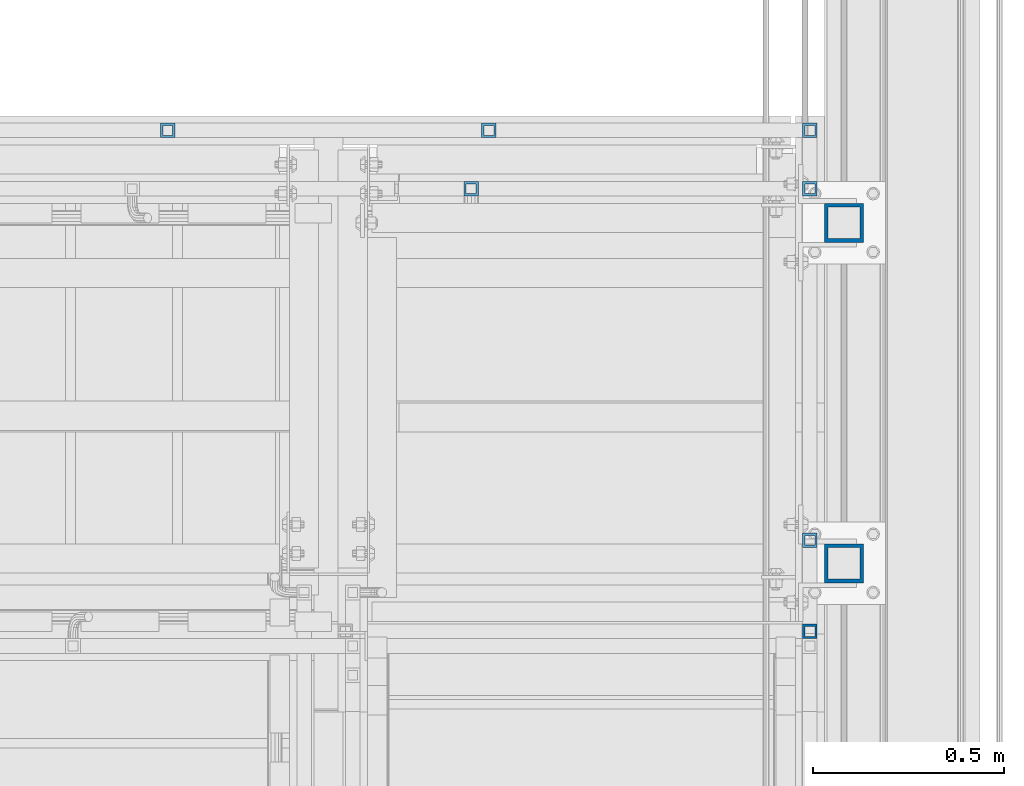
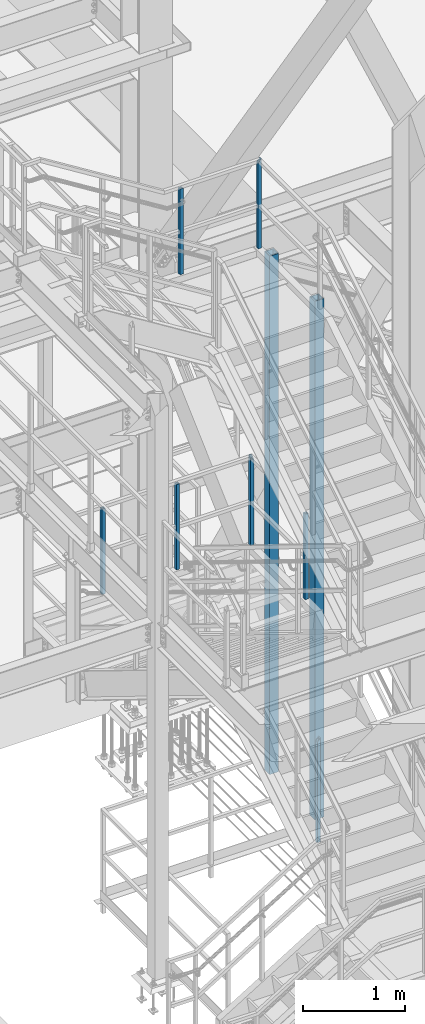
# One storey, part 1298 of 3843: 9 columns, 6 elements without a shape of their own.
"""IFC2X3 building model written with IfcOpenShell, lengths in millimetres."""

from ifc_helpers import new_model, si_unit, frame, origin_with_axes, place, context, subcontext, project, spatial, faceted_brep, material, type_object, element, aggregate, save


model = new_model("IFC2X3")

# Units and contexts
model_context = context("Model", 3, precision=1e-05, world=origin_with_axes())
body_context = subcontext(model_context, "Body", "Model", "MODEL_VIEW")
ifc_project = project(units=[si_unit("LENGTHUNIT", "METRE", prefix="MILLI"), si_unit("AREAUNIT", "SQUARE_METRE"), si_unit("VOLUMEUNIT", "CUBIC_METRE"), si_unit("MASSUNIT", "GRAM", prefix="KILO"), si_unit("TIMEUNIT", "SECOND"), si_unit("PLANEANGLEUNIT", "RADIAN"), si_unit("SOLIDANGLEUNIT", "STERADIAN"), si_unit("THERMODYNAMICTEMPERATUREUNIT", "DEGREE_CELSIUS"), si_unit("LUMINOUSINTENSITYUNIT", "LUMEN")], contexts=[model_context])

# Site, building, storey
site_placement = place(None, origin_with_axes())
site = spatial("IfcSite", under=ifc_project, at=site_placement, CompositionType="ELEMENT")
building_placement = place(site_placement, origin_with_axes())
building = spatial("IfcBuilding", under=site, at=building_placement, Name="Undefined", CompositionType="ELEMENT")
storey_placement = place(building_placement, origin_with_axes())
storey = spatial("IfcBuildingStorey", under=building, at=storey_placement, Name="Undefined", CompositionType="ELEMENT", Elevation=0.0)

# Assembly, column
assembly_1_placement = place(storey_placement, origin_with_axes())
assembly_1 = element("IfcElementAssembly", 1, at=assembly_1_placement, inside=storey, Name="RAIL", AssemblyPlace="NOTDEFINED", PredefinedType="RIGID_FRAME")
ifc_material_1 = material()
column_type_1 = type_object("IfcColumnType", Name="HSS1-1/2X1-1/2X1/4", PredefinedType="NOTDEFINED")
column_1_placement = place(assembly_1_placement, frame((55638.6999998292, 21755.0999999874, 30480.0), z_axis=(-1.0, 0.0, 0.0), x_axis=(0.0, 0.0, 1.0)))
column_1 = element("IfcColumn", 2, at=column_1_placement, type_object=column_type_1, material=ifc_material_1, Name="POST", ObjectType="HSS1-1/2X1-1/2X1/4", context=body_context, shape_type="Brep", body=[
    faceted_brep([(-152.399999977541, 12.6999993299978, -12.6999993299978), (-152.399999977541, -12.6999993299978, -12.6999993299978), (1079.49999933128, -12.6999993300014, -12.6999993299978), (1079.49999933128, 12.6999993300014, -12.6999993299978), (-152.399999977541, -12.6999993299978, 12.6999993299978), (1054.10000067129, -12.6999993300014, 12.6999993299978), (-152.399999977541, 12.6999993299978, 12.6999993299978), (1054.10000067129, 12.6999993300014, 12.6999993299978), (-152.399999977541, 19.0499992350015, -19.0499992349942), (-152.399999977541, 19.0499992350015, 19.0499992349942), (1047.75000076629, 19.0499992350015, 19.0499992349942), (1085.84999923629, 19.0499992350015, -19.0499992349942), (-152.399999977541, -19.0499992350015, 19.0499992349942), (1047.75000076629, -19.0499992350015, 19.0499992349942), (-152.399999977541, -19.0499992350015, -19.0499992349942), (1085.84999923629, -19.0499992350015, -19.0499992349942)], [[[0, 1, 2, 3]], [[1, 4, 5, 2]], [[4, 6, 7, 5]], [[6, 0, 3, 7]], [[8, 9, 10, 11]], [[9, 12, 13, 10]], [[12, 14, 15, 13]], [[14, 8, 11, 15]], [[13, 15, 11, 10], [5, 7, 3, 2]], [[14, 12, 9, 8], [6, 4, 1, 0]]]),
])
aggregate(assembly_1, [column_1])

# Assembly, columns
assembly_2_placement = place(storey_placement, origin_with_axes())
assembly_2 = element("IfcElementAssembly", 3, at=assembly_2_placement, inside=storey, Name="RAIL", AssemblyPlace="NOTDEFINED", PredefinedType="RIGID_FRAME")
column_2_placement = place(assembly_2_placement, frame((54753.9333333121, 22910.8000000151, 36694.5333312991), z_axis=(1.0, 0.0, 0.0), x_axis=(0.0, 0.0, 1.0)))
column_2 = element("IfcColumn", 4, at=column_2_placement, type_object=column_type_1, material=ifc_material_1, Name="POST", ObjectType="HSS1-1/2X1-1/2X1/4", context=body_context, shape_type="Brep", body=[
    faceted_brep([(1047.75000076629, -19.0499992350015, 19.0499992349942), (1047.750000765, -19.0499992350015, -19.0499992350015), (1047.750000765, 19.0499992350015, -19.0499992350015), (1047.75000076629, 19.0499992350015, 19.0499992349942), (1047.75000076497, -12.6999993300014, 12.6999993299978), (1047.75000076497, 12.6999993300014, 12.6999993299978), (1047.75000076497, 12.6999993300014, -12.6999993299978), (1047.75000076497, -12.6999993300014, -12.6999993299978), (25.4000000135893, 19.0499992350015, 19.0499992349942), (25.4000000135893, -19.0499992350015, 19.0499992349942), (25.4000000135893, -19.0499992350015, -19.0499992349942), (25.4000000135893, 19.0499992350015, -19.0499992349942), (25.4000000135893, 12.6999993300014, -12.6999993299978), (25.4000000135893, 12.6999993300014, 12.6999993299978), (25.4000000135893, -12.6999993300014, 12.6999993299978), (25.4000000135893, -12.6999993300014, -12.6999993299978)], [[[0, 1, 2, 3], [4, 5, 6, 7]], [[0, 3, 8, 9]], [[2, 1, 10, 11]], [[1, 0, 9, 10]], [[3, 2, 11, 8]], [[11, 10, 9, 8], [12, 13, 14, 15]], [[4, 7, 15, 14]], [[7, 6, 12, 15]], [[6, 5, 13, 12]], [[5, 4, 14, 13]]]),
])
column_3_placement = place(assembly_2_placement, frame((55638.700000001, 22910.8000000151, 36694.5333312991), z_axis=(1.0, 0.0, 0.0), x_axis=(0.0, 0.0, 1.0)))
column_3 = element("IfcColumn", 5, at=column_3_placement, type_object=column_type_1, material=ifc_material_1, Name="POST", ObjectType="HSS1-1/2X1-1/2X1/4", context=body_context, shape_type="Brep", body=[
    faceted_brep([(25.4000000135893, 12.6999993300014, -12.6999993299978), (25.4000000135893, -12.6999993300014, -12.6999993299978), (1054.10000067001, -12.6999993300014, -12.6999993299978), (1054.10000067001, 12.6999993300014, -12.6999993299978), (25.4000000135893, -12.6999993300014, 12.6999993299978), (1079.49999933, -12.6999993300014, 12.6999993299978), (25.4000000135893, 12.6999993300014, 12.6999993299978), (1079.49999933, 12.6999993300014, 12.6999993299978), (25.4000000135893, 19.0499992350015, -19.0499992349942), (25.4000000135893, 19.0499992350015, 19.0499992349942), (1085.849999235, 19.0499992350015, 19.0499992350015), (1047.750000765, 19.0499992350015, -19.0499992350015), (25.4000000135893, -19.0499992350015, 19.0499992349942), (1085.849999235, -19.0499992350015, 19.0499992350015), (25.4000000135893, -19.0499992350015, -19.0499992349942), (1047.750000765, -19.0499992350015, -19.0499992350015)], [[[0, 1, 2, 3]], [[1, 4, 5, 2]], [[4, 6, 7, 5]], [[6, 0, 3, 7]], [[8, 9, 10, 11]], [[9, 12, 13, 10]], [[12, 14, 15, 13]], [[11, 15, 14, 8]], [[13, 15, 11, 10], [5, 7, 3, 2]], [[8, 14, 12, 9], [0, 6, 4, 1]]]),
])
aggregate(assembly_2, [column_2, column_3])

assembly_3_placement = place(storey_placement, origin_with_axes())
assembly_3 = element("IfcElementAssembly", 6, at=assembly_3_placement, inside=storey, Name="RAIL", AssemblyPlace="NOTDEFINED", PredefinedType="RIGID_FRAME")
column_4_placement = place(assembly_3_placement, frame((53962.2999999994, 23063.2000000032, 33084.4769212707), z_axis=(0.0, -1.0, 0.0), x_axis=(0.0, 0.0, 1.0)))
column_4 = element("IfcColumn", 7, at=column_4_placement, type_object=column_type_1, material=ifc_material_1, Name="POST", ObjectType="HSS1-1/2X1-1/2X1/4", context=body_context, shape_type="Brep", body=[
    faceted_brep([(0.0, 12.6999993299978, -12.6999993300014), (0.0, -12.6999993299978, -12.6999993300014), (1022.35000076501, -12.6999993299978, -12.6999993300014), (1022.35000076501, 12.6999993299978, -12.6999993300014), (0.0, -12.6999993299978, 12.6999993300014), (1022.35000076501, -12.6999993299978, 12.6999993300014), (0.0, 12.6999993299978, 12.6999993300014), (1022.35000076501, 12.6999993299978, 12.6999993300014), (0.0, 19.0500000000029, -19.0499999999993), (0.0, 19.0499992350015, 19.0499992350015), (1022.35000076501, 19.0499992350015, 19.0499992350015), (1022.35000076501, 19.0499992350015, -19.0499992350015), (0.0, -19.0499992350015, 19.0499992350015), (1022.35000076501, -19.0499992350015, 19.0499992350015), (0.0, -19.0499992350015, -19.0499992350015), (1022.35000076501, -19.0499992350015, -19.0499992350015)], [[[0, 1, 2, 3]], [[1, 4, 5, 2]], [[4, 6, 7, 5]], [[6, 0, 3, 7]], [[8, 9, 10, 11]], [[9, 12, 13, 10]], [[12, 14, 15, 13]], [[14, 8, 11, 15]], [[13, 15, 11, 10], [5, 7, 3, 2]], [[14, 12, 9, 8], [6, 4, 1, 0]]]),
])
column_5_placement = place(assembly_3_placement, frame((54800.4999999997, 23063.2000000032, 33084.4769212707), z_axis=(0.0, -1.0, 0.0), x_axis=(0.0, 0.0, 1.0)))
column_5 = element("IfcColumn", 8, at=column_5_placement, type_object=column_type_1, material=ifc_material_1, Name="POST", ObjectType="HSS1-1/2X1-1/2X1/4", context=body_context, shape_type="Brep", body=[
    faceted_brep([(0.0, 12.6999993299978, -12.6999993300014), (0.0, -12.6999993299978, -12.6999993300014), (1022.35000076501, -12.6999993299978, -12.6999993300014), (1022.35000076501, 12.6999993299978, -12.6999993300014), (0.0, -12.6999993299978, 12.6999993300014), (1022.35000076501, -12.6999993299978, 12.6999993300014), (0.0, 12.6999993299978, 12.6999993300014), (1022.35000076501, 12.6999993299978, 12.6999993300014), (0.0, 19.0500000000029, -19.0499999999993), (0.0, 19.0499992350015, 19.0499992350015), (1022.35000076501, 19.0499992350015, 19.0499992350015), (1022.35000076501, 19.0499992350015, -19.0499992350015), (0.0, -19.0499992350015, 19.0499992350015), (1022.35000076501, -19.0499992350015, 19.0499992350015), (0.0, -19.0499992350015, -19.0499992350015), (1022.35000076501, -19.0499992350015, -19.0499992350015)], [[[0, 1, 2, 3]], [[1, 4, 5, 2]], [[4, 6, 7, 5]], [[6, 0, 3, 7]], [[8, 9, 10, 11]], [[9, 12, 13, 10]], [[12, 14, 15, 13]], [[14, 8, 11, 15]], [[13, 15, 11, 10], [5, 7, 3, 2]], [[14, 12, 9, 8], [6, 4, 1, 0]]]),
])
aggregate(assembly_3, [column_4, column_5])

assembly_4_placement = place(storey_placement, origin_with_axes())
assembly_4 = element("IfcElementAssembly", 9, at=assembly_4_placement, inside=storey, Name="RAIL", AssemblyPlace="NOTDEFINED", PredefinedType="RIGID_FRAME")
column_6_placement = place(assembly_4_placement, frame((55638.7, 23063.2000000032, 33059.0769213117), z_axis=(0.0, -1.0, 0.0), x_axis=(0.0, 0.0, 1.0)))
column_6 = element("IfcColumn", 10, at=column_6_placement, type_object=column_type_1, material=ifc_material_1, Name="POST", ObjectType="HSS1-1/2X1-1/2X1/4", context=body_context, shape_type="Brep", body=[
    faceted_brep([(1047.75000076629, -19.0499992350015, 19.0499992349942), (1047.75000076629, 19.0499992350015, 19.0499992349942), (25.4000000135893, 19.0499992350015, 19.0499992349942), (25.4000000135893, -19.0499992350015, 19.0499992349942), (1085.84999923629, -19.0499992350015, -19.0499992349942), (25.4000000135893, -19.0499992350015, -19.0499992349942), (1085.84999923629, 19.0499992350015, -19.0499992349942), (25.4000000135893, 19.0499992350015, -19.0499992349942), (1054.10000067129, -12.6999993300014, 12.6999993299978), (1054.10000067129, 12.6999993300014, 12.6999993299978), (1079.49999933128, 12.6999993300014, -12.6999993299978), (1079.49999933128, -12.6999993300014, -12.6999993299978), (25.4000000135893, -12.6999993300014, 12.6999993299978), (25.4000000135893, 12.6999993300014, 12.6999993299978), (25.4000000135893, 12.6999993300014, -12.6999993299978), (25.4000000135893, -12.6999993300014, -12.6999993299978)], [[[0, 1, 2, 3]], [[4, 0, 3, 5]], [[6, 4, 5, 7]], [[1, 6, 7, 2]], [[0, 4, 6, 1], [8, 9, 10, 11]], [[9, 8, 12, 13]], [[10, 9, 13, 14]], [[11, 10, 14, 15]], [[8, 11, 15, 12]], [[7, 5, 3, 2], [14, 13, 12, 15]]]),
])
column_7_placement = place(assembly_4_placement, frame((55638.7, 21993.2250000024, 33059.0769213117), z_axis=(0.0, -1.0, 0.0), x_axis=(0.0, 0.0, 1.0)))
column_7 = element("IfcColumn", 11, at=column_7_placement, type_object=column_type_1, material=ifc_material_1, Name="POST", ObjectType="HSS1-1/2X1-1/2X1/4", context=body_context, shape_type="Brep", body=[
    faceted_brep([(1047.75000076629, -19.0499992350015, 19.0499992349942), (1047.75000076629, 19.0499992350015, 19.0499992349942), (25.4000000135893, 19.0499992350015, 19.0499992349942), (25.4000000135893, -19.0499992350015, 19.0499992349942), (1047.750000765, -19.0499992350015, -19.0499992350015), (25.4000000135893, -19.0499992350015, -19.0499992349942), (1047.750000765, 19.0499992350015, -19.0499992350015), (25.4000000135893, 19.0499992350015, -19.0499992349942), (1047.75000076497, -12.6999993300014, 12.6999993299978), (1047.75000076497, 12.6999993300014, 12.6999993299978), (1047.75000076497, 12.6999993300014, -12.6999993299978), (1047.75000076497, -12.6999993300014, -12.6999993299978), (25.4000000135893, -12.6999993300014, 12.6999993299978), (25.4000000135893, 12.6999993300014, 12.6999993299978), (25.4000000135893, 12.6999993300014, -12.6999993299978), (25.4000000135893, -12.6999993300014, -12.6999993299978)], [[[0, 1, 2, 3]], [[4, 0, 3, 5]], [[6, 4, 5, 7]], [[1, 6, 7, 2]], [[0, 4, 6, 1], [8, 9, 10, 11]], [[9, 8, 12, 13]], [[10, 9, 13, 14]], [[11, 10, 14, 15]], [[8, 11, 15, 12]], [[7, 5, 3, 2], [14, 13, 12, 15]]]),
])
aggregate(assembly_4, [column_6, column_7])

# Assembly, column
assembly_5_placement = place(storey_placement, origin_with_axes())
assembly_5 = element("IfcElementAssembly", 12, at=assembly_5_placement, inside=storey, Name="POST", AssemblyPlace="NOTDEFINED", PredefinedType="RIGID_FRAME")
ifc_material_2 = material()
column_type_2 = type_object("IfcColumnType", Name="HSS4X4X3/8", PredefinedType="NOTDEFINED")
column_8_placement = place(assembly_5_placement, frame((55727.5999999994, 22821.9000000818, 30480.0), z_axis=(-1.0, 0.0, 0.0), x_axis=(0.0, 0.0, 1.0)))
column_8 = element("IfcColumn", 13, at=column_8_placement, type_object=column_type_2, material=ifc_material_2, Name="POST", ObjectType="HSS4X4X3/8", context=body_context, shape_type="Brep", body=[
    faceted_brep([(12.7000000000007, 41.2750000000015, -41.2750000000015), (12.7000000000007, -41.2750000000015, -41.2750000000015), (6205.00833130307, -41.2750000000015, -41.2750000000015), (6205.00833130307, 41.2750000000015, -41.2750000000015), (12.7000000000007, -41.2750000000015, 41.2750000000015), (6205.00833130307, -41.2750000000015, 41.2750000000015), (12.7000000000007, 41.2750000000015, 41.2750000000015), (6205.00833130307, 41.2750000000015, 41.2750000000015), (12.7000000000007, 50.7999999999993, -50.8000000000029), (12.7000000000007, 50.7999999999993, 50.8000000000029), (6205.00833130307, 50.7999999999993, 50.8000000000029), (6205.00833130307, 50.7999999999993, -50.8000000000029), (12.7000000000007, -50.7999999999993, 50.8000000000029), (6205.00833130307, -50.7999999999993, 50.8000000000029), (12.7000000000007, -50.7999999999993, -50.8000000000029), (6205.00833130307, -50.7999999999993, -50.8000000000029)], [[[0, 1, 2, 3]], [[1, 4, 5, 2]], [[4, 6, 7, 5]], [[6, 0, 3, 7]], [[8, 9, 10, 11]], [[9, 12, 13, 10]], [[12, 14, 15, 13]], [[14, 8, 11, 15]], [[13, 15, 11, 10], [5, 7, 3, 2]], [[14, 12, 9, 8], [6, 4, 1, 0]]]),
])
aggregate(assembly_5, [column_8])

assembly_6_placement = place(storey_placement, origin_with_axes())
assembly_6 = element("IfcElementAssembly", 14, at=assembly_6_placement, inside=storey, Name="POST", AssemblyPlace="NOTDEFINED", PredefinedType="RIGID_FRAME")
column_9_placement = place(assembly_6_placement, frame((55727.5999999994, 21932.9000000032, 30480.0), z_axis=(-1.0, 0.0, 0.0), x_axis=(0.0, 0.0, 1.0)))
column_9 = element("IfcColumn", 15, at=column_9_placement, type_object=column_type_2, material=ifc_material_2, Name="POST", ObjectType="HSS4X4X3/8", context=body_context, shape_type="Brep", body=[
    faceted_brep([(12.7000000000007, 41.2750000000015, -41.2750000000015), (12.7000000000007, -41.2750000000015, -41.2750000000015), (6205.00833130307, -41.2750000000015, -41.2750000000015), (6205.00833130307, 41.2750000000015, -41.2750000000015), (12.7000000000007, -41.2750000000015, 41.2750000000015), (6205.00833130307, -41.2750000000015, 41.2750000000015), (12.7000000000007, 41.2750000000015, 41.2750000000015), (6205.00833130307, 41.2750000000015, 41.2750000000015), (12.7000000000007, 50.7999999999993, -50.8000000000029), (12.7000000000007, 50.7999999999993, 50.8000000000029), (6205.00833130307, 50.7999999999993, 50.8000000000029), (6205.00833130307, 50.7999999999993, -50.8000000000029), (12.7000000000007, -50.7999999999993, 50.8000000000029), (6205.00833130307, -50.7999999999993, 50.8000000000029), (12.7000000000007, -50.7999999999993, -50.8000000000029), (6205.00833130307, -50.7999999999993, -50.8000000000029)], [[[0, 1, 2, 3]], [[1, 4, 5, 2]], [[4, 6, 7, 5]], [[6, 0, 3, 7]], [[8, 9, 10, 11]], [[9, 12, 13, 10]], [[12, 14, 15, 13]], [[14, 8, 11, 15]], [[13, 15, 11, 10], [5, 7, 3, 2]], [[14, 12, 9, 8], [6, 4, 1, 0]]]),
])
aggregate(assembly_6, [column_9])

save(model, "model.ifc")
